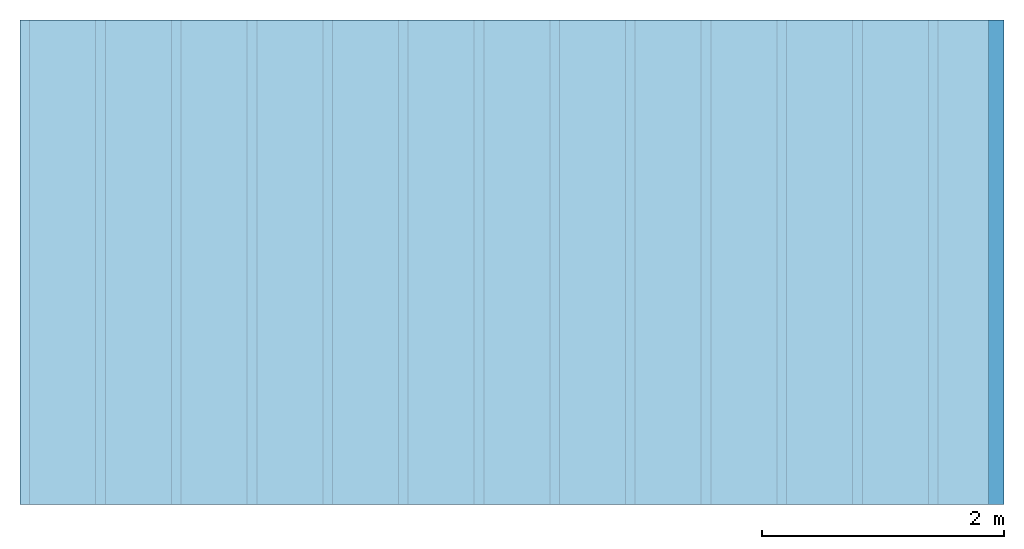
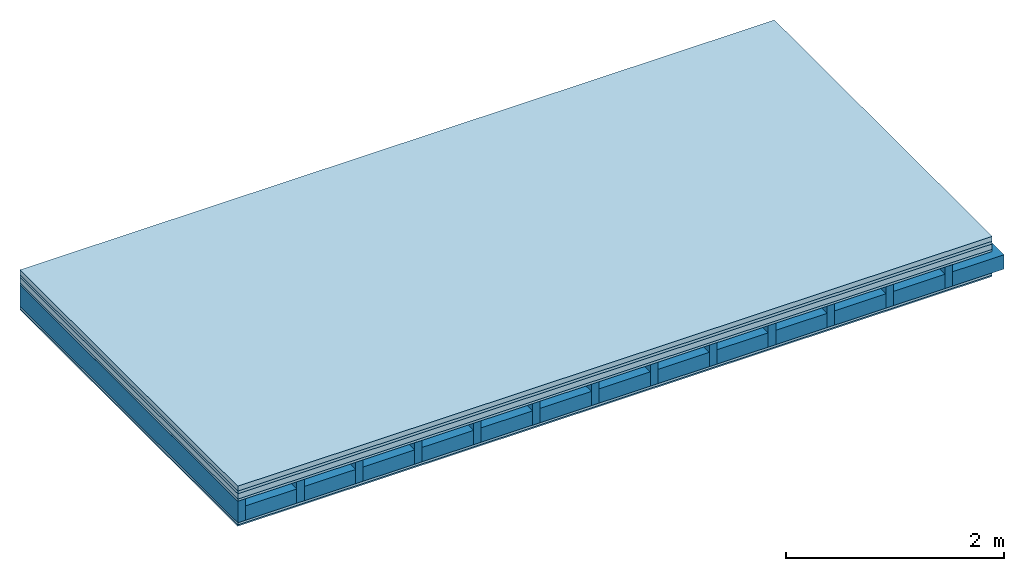
# One storey: 6 plates, 2 members, 1 element without a shape of its own.
"""IFC4 building model written with IfcOpenShell, lengths in metres."""

from ifc_helpers import new_model, si_unit, derived_unit, direction, frame, frame_2d, origin, origin_with_axes, place, context, project, spatial, rectangle, extrude, material, layer, layer_set, type_object, element, aggregate, save


model = new_model("IFC4")

# Units and contexts
plan_context = context("Plan", 3, precision=1e-05, world=origin(), true_north=direction((0.0, 1.0)))
model_context = context("Model", 3, precision=1e-05, world=origin(), true_north=direction((0.0, 1.0)))
ifc_project = project(units=[si_unit("LENGTHUNIT", "METRE"), derived_unit("SOUNDPRESSUREUNIT", [(si_unit("PRESSUREUNIT", "PASCAL", prefix="MICRO"), 0)]), si_unit("ENERGYUNIT", "JOULE", prefix="MEGA"), si_unit("MASSUNIT", "GRAM", prefix="KILO"), derived_unit("THERMALTRANSMITTANCEUNIT", [(si_unit("POWERUNIT", "WATT"), 1), (si_unit("AREAUNIT", "SQUARE_METRE"), -1), (si_unit("THERMODYNAMICTEMPERATUREUNIT", "KELVIN"), -1)]), derived_unit("AREADENSITYUNIT", [(si_unit("MASSUNIT", "GRAM", prefix="KILO"), 1), (si_unit("AREAUNIT", "SQUARE_METRE"), -1)]), derived_unit("USERDEFINED", [(si_unit("ENERGYUNIT", "JOULE", prefix="MEGA"), 1), (si_unit("AREAUNIT", "SQUARE_METRE"), -1)])], contexts=[plan_context, model_context])

# Site, building, storey
site = spatial("IfcSite", under=ifc_project)
building_placement = place(None, origin())
building = spatial("IfcBuilding", under=site, at=building_placement)
storey_placement = place(building_placement, origin())
storey = spatial("IfcBuildingStorey", under=building, at=storey_placement)

# Slab, members, plates
ifc_material_1 = material(Category="04.005")
ifc_layer_1 = layer(ifc_material_1, 0.055, Name="On-material")
ifc_material_2 = material()
ifc_layer_2 = layer(ifc_material_2, 0.03, Name="Impact sound insulation")
ifc_material_3 = material(Category="03.011")
ifc_layer_3 = layer(ifc_material_3, 0.06, Name="on Supporting structure")
ifc_material_4 = material(Category="07.001")
ifc_layer_4 = layer(ifc_material_4, 0.025, Name="Sub-floor")
ifc_material_5 = material(Name="Rigid, of the art")
ifc_layer_5 = layer(ifc_material_5, 0.0, Name="Bond")
ifc_layer_6 = layer(None, 0.24, Name="Supporting structure")
ifc_layer_7 = layer(ifc_material_5, 0.0, Name="Bond")
ifc_layer_8 = layer(ifc_material_4, 0.025, Name="Lower layer 1")
ifc_material_6 = material(Category="03.007")
ifc_layer_9 = layer(ifc_material_6, 0.015, Name="Lower 2nd layer")
ifc_layer_set = layer_set([ifc_layer_1, ifc_layer_2, ifc_layer_3, ifc_layer_4, ifc_layer_5, ifc_layer_6, ifc_layer_7, ifc_layer_8, ifc_layer_9])
slab_type = type_object("IfcSlabType", Name="A0446", PredefinedType="NOTDEFINED", material=ifc_layer_set)
slab_placement = place(None, frame((0.0, 0.0, 0.0), z_axis=(0.0, 0.0, -1.0), x_axis=(1.0, 0.0, 0.0)))
slab = element("IfcSlab", 1, at=slab_placement, inside=storey, type_object=slab_type, material=ifc_layer_set, Name="Slab #1")
ifc_material_7 = material()
member_1_placement = place(slab_placement, origin())
member_1 = element("IfcMember", 2, at=member_1_placement, material=ifc_material_7, Name="Supporting structure", context=plan_context, shape_type="SweptSolid", body=[
    extrude(rectangle(XDim=0.08, YDim=0.24, at=frame_2d((0.04, 0.12), x_axis=(1.0, 0.0))), frame((0.0, 4.0, 0.17), z_axis=(0.0, -1.0, 0.0), x_axis=(1.0, 0.0, 0.0)), (0.0, 0.0, 1.0), 4.0),
    extrude(rectangle(XDim=0.08, YDim=0.24, at=frame_2d((0.04, 0.12), x_axis=(1.0, 0.0))), frame((0.625, 4.0, 0.17), z_axis=(0.0, -1.0, 0.0), x_axis=(1.0, 0.0, 0.0)), (0.0, 0.0, 1.0), 4.0),
    extrude(rectangle(XDim=0.08, YDim=0.24, at=frame_2d((0.04, 0.12), x_axis=(1.0, 0.0))), frame((1.25, 4.0, 0.17), z_axis=(0.0, -1.0, 0.0), x_axis=(1.0, 0.0, 0.0)), (0.0, 0.0, 1.0), 4.0),
    extrude(rectangle(XDim=0.08, YDim=0.24, at=frame_2d((0.04, 0.12), x_axis=(1.0, 0.0))), frame((1.875, 4.0, 0.17), z_axis=(0.0, -1.0, 0.0), x_axis=(1.0, 0.0, 0.0)), (0.0, 0.0, 1.0), 4.0),
    extrude(rectangle(XDim=0.08, YDim=0.24, at=frame_2d((0.04, 0.12), x_axis=(1.0, 0.0))), frame((2.5, 4.0, 0.17), z_axis=(0.0, -1.0, 0.0), x_axis=(1.0, 0.0, 0.0)), (0.0, 0.0, 1.0), 4.0),
    extrude(rectangle(XDim=0.08, YDim=0.24, at=frame_2d((0.04, 0.12), x_axis=(1.0, 0.0))), frame((3.125, 4.0, 0.17), z_axis=(0.0, -1.0, 0.0), x_axis=(1.0, 0.0, 0.0)), (0.0, 0.0, 1.0), 4.0),
    extrude(rectangle(XDim=0.08, YDim=0.24, at=frame_2d((0.04, 0.12), x_axis=(1.0, 0.0))), frame((3.75, 4.0, 0.17), z_axis=(0.0, -1.0, 0.0), x_axis=(1.0, 0.0, 0.0)), (0.0, 0.0, 1.0), 4.0),
    extrude(rectangle(XDim=0.08, YDim=0.24, at=frame_2d((0.04, 0.12), x_axis=(1.0, 0.0))), frame((4.375, 4.0, 0.17), z_axis=(0.0, -1.0, 0.0), x_axis=(1.0, 0.0, 0.0)), (0.0, 0.0, 1.0), 4.0),
    extrude(rectangle(XDim=0.08, YDim=0.24, at=frame_2d((0.04, 0.12), x_axis=(1.0, 0.0))), frame((5.0, 4.0, 0.17), z_axis=(0.0, -1.0, 0.0), x_axis=(1.0, 0.0, 0.0)), (0.0, 0.0, 1.0), 4.0),
    extrude(rectangle(XDim=0.08, YDim=0.24, at=frame_2d((0.04, 0.12), x_axis=(1.0, 0.0))), frame((5.625, 4.0, 0.17), z_axis=(0.0, -1.0, 0.0), x_axis=(1.0, 0.0, 0.0)), (0.0, 0.0, 1.0), 4.0),
    extrude(rectangle(XDim=0.08, YDim=0.24, at=frame_2d((0.04, 0.12), x_axis=(1.0, 0.0))), frame((6.25, 4.0, 0.17), z_axis=(0.0, -1.0, 0.0), x_axis=(1.0, 0.0, 0.0)), (0.0, 0.0, 1.0), 4.0),
    extrude(rectangle(XDim=0.08, YDim=0.24, at=frame_2d((0.04, 0.12), x_axis=(1.0, 0.0))), frame((6.875, 4.0, 0.17), z_axis=(0.0, -1.0, 0.0), x_axis=(1.0, 0.0, 0.0)), (0.0, 0.0, 1.0), 4.0),
    extrude(rectangle(XDim=0.08, YDim=0.24, at=frame_2d((0.04, 0.12), x_axis=(1.0, 0.0))), frame((7.5, 4.0, 0.17), z_axis=(0.0, -1.0, 0.0), x_axis=(1.0, 0.0, 0.0)), (0.0, 0.0, 1.0), 4.0),
])
ifc_material_8 = material()
member_2_placement = place(slab_placement, origin())
member_2 = element("IfcMember", 3, at=member_2_placement, material=ifc_material_8, Name="Cavity", context=plan_context, shape_type="SweptSolid", body=[
    extrude(rectangle(XDim=0.545, YDim=0.16, at=frame_2d((0.2725, 0.08), x_axis=(1.0, 0.0))), frame((0.08, 4.0, 0.25), z_axis=(0.0, -1.0, 0.0), x_axis=(1.0, 0.0, 0.0)), (0.0, 0.0, 1.0), 4.0),
    extrude(rectangle(XDim=0.545, YDim=0.16, at=frame_2d((0.2725, 0.08), x_axis=(1.0, 0.0))), frame((0.705, 4.0, 0.25), z_axis=(0.0, -1.0, 0.0), x_axis=(1.0, 0.0, 0.0)), (0.0, 0.0, 1.0), 4.0),
    extrude(rectangle(XDim=0.545, YDim=0.16, at=frame_2d((0.2725, 0.08), x_axis=(1.0, 0.0))), frame((1.33, 4.0, 0.25), z_axis=(0.0, -1.0, 0.0), x_axis=(1.0, 0.0, 0.0)), (0.0, 0.0, 1.0), 4.0),
    extrude(rectangle(XDim=0.545, YDim=0.16, at=frame_2d((0.2725, 0.08), x_axis=(1.0, 0.0))), frame((1.955, 4.0, 0.25), z_axis=(0.0, -1.0, 0.0), x_axis=(1.0, 0.0, 0.0)), (0.0, 0.0, 1.0), 4.0),
    extrude(rectangle(XDim=0.545, YDim=0.16, at=frame_2d((0.2725, 0.08), x_axis=(1.0, 0.0))), frame((2.58, 4.0, 0.25), z_axis=(0.0, -1.0, 0.0), x_axis=(1.0, 0.0, 0.0)), (0.0, 0.0, 1.0), 4.0),
    extrude(rectangle(XDim=0.545, YDim=0.16, at=frame_2d((0.2725, 0.08), x_axis=(1.0, 0.0))), frame((3.205, 4.0, 0.25), z_axis=(0.0, -1.0, 0.0), x_axis=(1.0, 0.0, 0.0)), (0.0, 0.0, 1.0), 4.0),
    extrude(rectangle(XDim=0.545, YDim=0.16, at=frame_2d((0.2725, 0.08), x_axis=(1.0, 0.0))), frame((3.83, 4.0, 0.25), z_axis=(0.0, -1.0, 0.0), x_axis=(1.0, 0.0, 0.0)), (0.0, 0.0, 1.0), 4.0),
    extrude(rectangle(XDim=0.545, YDim=0.16, at=frame_2d((0.2725, 0.08), x_axis=(1.0, 0.0))), frame((4.455, 4.0, 0.25), z_axis=(0.0, -1.0, 0.0), x_axis=(1.0, 0.0, 0.0)), (0.0, 0.0, 1.0), 4.0),
    extrude(rectangle(XDim=0.545, YDim=0.16, at=frame_2d((0.2725, 0.08), x_axis=(1.0, 0.0))), frame((5.08, 4.0, 0.25), z_axis=(0.0, -1.0, 0.0), x_axis=(1.0, 0.0, 0.0)), (0.0, 0.0, 1.0), 4.0),
    extrude(rectangle(XDim=0.545, YDim=0.16, at=frame_2d((0.2725, 0.08), x_axis=(1.0, 0.0))), frame((5.705, 4.0, 0.25), z_axis=(0.0, -1.0, 0.0), x_axis=(1.0, 0.0, 0.0)), (0.0, 0.0, 1.0), 4.0),
    extrude(rectangle(XDim=0.545, YDim=0.16, at=frame_2d((0.2725, 0.08), x_axis=(1.0, 0.0))), frame((6.33, 4.0, 0.25), z_axis=(0.0, -1.0, 0.0), x_axis=(1.0, 0.0, 0.0)), (0.0, 0.0, 1.0), 4.0),
    extrude(rectangle(XDim=0.545, YDim=0.16, at=frame_2d((0.2725, 0.08), x_axis=(1.0, 0.0))), frame((6.955, 4.0, 0.25), z_axis=(0.0, -1.0, 0.0), x_axis=(1.0, 0.0, 0.0)), (0.0, 0.0, 1.0), 4.0),
    extrude(rectangle(XDim=0.545, YDim=0.16, at=frame_2d((0.2725, 0.08), x_axis=(1.0, 0.0))), frame((7.58, 4.0, 0.25), z_axis=(0.0, -1.0, 0.0), x_axis=(1.0, 0.0, 0.0)), (0.0, 0.0, 1.0), 4.0),
])
plate_1_placement = place(slab_placement, origin())
plate_1 = element("IfcPlate", 4, at=plate_1_placement, material=ifc_material_1, Name="On-material", context=plan_context, shape_type="SweptSolid", body=[
    extrude(rectangle(XDim=8.0, YDim=4.0, at=frame_2d((4.0, 2.0), x_axis=(1.0, 0.0))), origin_with_axes(), (0.0, 0.0, 1.0), 0.055),
])
plate_2_placement = place(slab_placement, origin())
plate_2 = element("IfcPlate", 5, at=plate_2_placement, material=ifc_material_2, Name="Impact sound insulation", context=plan_context, shape_type="SweptSolid", body=[
    extrude(rectangle(XDim=8.0, YDim=4.0, at=frame_2d((4.0, 2.0), x_axis=(1.0, 0.0))), frame((0.0, 0.0, 0.055), z_axis=(0.0, 0.0, 1.0), x_axis=(1.0, 0.0, 0.0)), (0.0, 0.0, 1.0), 0.03),
])
plate_3_placement = place(slab_placement, origin())
plate_3 = element("IfcPlate", 6, at=plate_3_placement, material=ifc_material_3, Name="on Supporting structure", context=plan_context, shape_type="SweptSolid", body=[
    extrude(rectangle(XDim=8.0, YDim=4.0, at=frame_2d((4.0, 2.0), x_axis=(1.0, 0.0))), frame((0.0, 0.0, 0.085), z_axis=(0.0, 0.0, 1.0), x_axis=(1.0, 0.0, 0.0)), (0.0, 0.0, 1.0), 0.06),
])
plate_4_placement = place(slab_placement, origin())
plate_4 = element("IfcPlate", 7, at=plate_4_placement, material=ifc_material_4, Name="Sub-floor", context=plan_context, shape_type="SweptSolid", body=[
    extrude(rectangle(XDim=8.0, YDim=4.0, at=frame_2d((4.0, 2.0), x_axis=(1.0, 0.0))), frame((0.0, 0.0, 0.145), z_axis=(0.0, 0.0, 1.0), x_axis=(1.0, 0.0, 0.0)), (0.0, 0.0, 1.0), 0.025),
])
plate_5_placement = place(slab_placement, origin())
plate_5 = element("IfcPlate", 8, at=plate_5_placement, material=ifc_material_4, Name="Lower layer 1", context=plan_context, shape_type="SweptSolid", body=[
    extrude(rectangle(XDim=8.0, YDim=4.0, at=frame_2d((4.0, 2.0), x_axis=(1.0, 0.0))), frame((0.0, 0.0, 0.41), z_axis=(0.0, 0.0, 1.0), x_axis=(1.0, 0.0, 0.0)), (0.0, 0.0, 1.0), 0.025),
])
plate_6_placement = place(slab_placement, origin())
plate_6 = element("IfcPlate", 9, at=plate_6_placement, material=ifc_material_6, Name="Lower 2nd layer", context=plan_context, shape_type="SweptSolid", body=[
    extrude(rectangle(XDim=8.0, YDim=4.0, at=frame_2d((4.0, 2.0), x_axis=(1.0, 0.0))), frame((0.0, 0.0, 0.435), z_axis=(0.0, 0.0, 1.0), x_axis=(1.0, 0.0, 0.0)), (0.0, 0.0, 1.0), 0.015),
])
aggregate(slab, [plate_1, plate_2, plate_3, plate_4, member_1, member_2, plate_5, plate_6])

save(model, "model.ifc")
